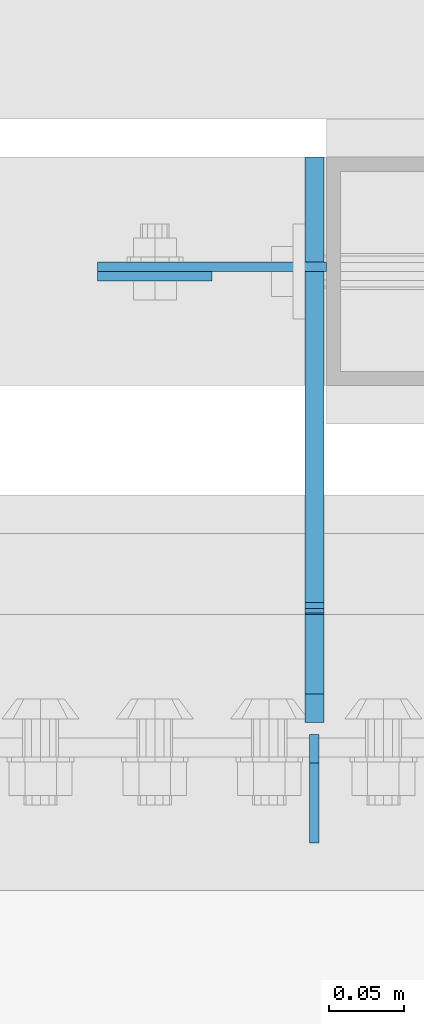
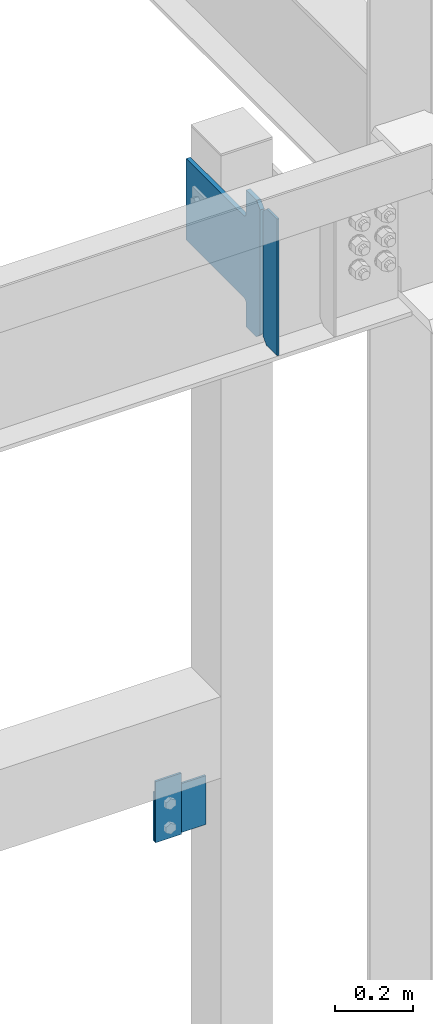
# One storey, part 3459 of 3843: 4 plates, 3 elements without a shape of their own.
"""IFC2X3 building model written with IfcOpenShell, lengths in millimetres."""

from ifc_helpers import new_model, si_unit, frame, origin_with_axes, place, context, subcontext, project, spatial, faceted_brep, material, type_object, element, aggregate, save


model = new_model("IFC2X3")

# Units and contexts
model_context = context("Model", 3, precision=1e-05, world=origin_with_axes())
body_context = subcontext(model_context, "Body", "Model", "MODEL_VIEW")
ifc_project = project(units=[si_unit("LENGTHUNIT", "METRE", prefix="MILLI"), si_unit("AREAUNIT", "SQUARE_METRE"), si_unit("VOLUMEUNIT", "CUBIC_METRE"), si_unit("MASSUNIT", "GRAM", prefix="KILO"), si_unit("TIMEUNIT", "SECOND"), si_unit("PLANEANGLEUNIT", "RADIAN"), si_unit("SOLIDANGLEUNIT", "STERADIAN"), si_unit("THERMODYNAMICTEMPERATUREUNIT", "DEGREE_CELSIUS"), si_unit("LUMINOUSINTENSITYUNIT", "LUMEN")], contexts=[model_context])

# Site, building, storey
site_placement = place(None, origin_with_axes())
site = spatial("IfcSite", under=ifc_project, at=site_placement, CompositionType="ELEMENT")
building_placement = place(site_placement, origin_with_axes())
building = spatial("IfcBuilding", under=site, at=building_placement, Name="Undefined", CompositionType="ELEMENT")
storey_placement = place(building_placement, origin_with_axes())
storey = spatial("IfcBuildingStorey", under=building, at=storey_placement, Name="Undefined", CompositionType="ELEMENT", Elevation=0.0)

# Assembly, plate
assembly_1_placement = place(storey_placement, origin_with_axes())
assembly_1 = element("IfcElementAssembly", 1, at=assembly_1_placement, inside=storey, Name="POST", AssemblyPlace="NOTDEFINED", PredefinedType="RIGID_FRAME")
ifc_material = material(Name="STEEL/A572-50")
plate_type_1 = type_object("IfcPlateType", PredefinedType="NOTDEFINED")
plate_1_placement = place(assembly_1_placement, frame((48412.4, 92522.675, 34455.1), z_axis=(0.0, 0.0, -1.0), x_axis=(-1.0, 0.0, 0.0)))
plate_1 = element("IfcPlate", 2, at=plate_1_placement, type_object=plate_type_1, material=ifc_material, Name="PLATE", context=body_context, shape_type="Brep", body=[
    faceted_brep([(0.0, -3.17499999999927, 0.0), (1.52795109897852e-10, -3.17500000000291, 152.400000000009), (1.52795109897852e-10, 3.17500000000291, 152.400000000009), (0.0, 3.17499999999927, 0.0), (152.399993896484, -3.17500000000291, 152.399993896484), (152.399993896484, 3.17500000000291, 152.399993896484), (152.399998474109, -3.17500000000291, 0.0), (152.399998474109, 3.17500000000291, 0.0)], [[[0, 1, 2, 3]], [[1, 4, 5, 2]], [[4, 6, 7, 5]], [[6, 0, 3, 7]], [[5, 7, 3, 2]], [[6, 4, 1, 0]]]),
])
aggregate(assembly_1, [plate_1])

assembly_2_placement = place(storey_placement, origin_with_axes())
assembly_2 = element("IfcElementAssembly", 3, at=assembly_2_placement, inside=storey, Name="BEAM", AssemblyPlace="NOTDEFINED", PredefinedType="RIGID_FRAME")
plate_type_2 = type_object("IfcPlateType", PredefinedType="NOTDEFINED")
plate_2_placement = place(assembly_2_placement, frame((48260.0000061035, 92516.325, 34302.7000061036), z_axis=(1.0, 0.0, 0.0), x_axis=(0.0, 0.0, 1.0)))
plate_2 = element("IfcPlate", 4, at=plate_2_placement, type_object=plate_type_2, material=ifc_material, Name="PLATE", context=body_context, shape_type="Brep", body=[
    faceted_brep([(0.0, -3.17499999999927, 0.0), (0.0, -3.17499999999927, 76.1999969482422), (0.0, 3.17499999999927, 76.1999969482422), (0.0, 3.17499999999927, 0.0), (190.5, -3.17500000000291, 76.1999969482422), (190.5, 3.17500000000291, 76.1999969482422), (190.5, -3.17500000000291, -3.63797880709171e-12), (190.5, 3.17500000000291, -3.63797880709171e-12)], [[[0, 1, 2, 3]], [[1, 4, 5, 2]], [[4, 6, 7, 5]], [[6, 0, 3, 7]], [[5, 7, 3, 2]], [[6, 4, 1, 0]]]),
])
aggregate(assembly_2, [plate_2])

# Assembly, plates
assembly_3_placement = place(storey_placement, origin_with_axes())
assembly_3 = element("IfcElementAssembly", 5, at=assembly_3_placement, inside=storey, Name="BEAM", AssemblyPlace="NOTDEFINED", PredefinedType="RIGID_FRAME")
plate_type_3 = type_object("IfcPlateType", PredefinedType="NOTDEFINED")
plate_3_placement = place(assembly_3_placement, frame((48404.4625, 92138.5, 35996.5625), z_axis=(0.0, 0.0, 1.0), x_axis=(0.0, 1.0, 0.0)))
plate_3 = element("IfcPlate", 6, at=plate_3_placement, type_object=plate_type_3, material=ifc_material, Name="PLATE", context=body_context, shape_type="Brep", body=[
    faceted_brep([(0.0, -3.17499999999927, 0.0), (0.0, -3.17500000000291, 425.449999999997), (0.0, 3.17500000000291, 425.449999999997), (0.0, 3.17499999999927, 0.0), (53.1812477111816, -3.17500000000291, 425.450012207031), (53.1812477111816, 3.17500000000291, 425.450012207031), (72.2312469482422, -3.17500000000291, 406.400012969971), (72.2312469482422, 3.17500000000291, 406.400012969971), (72.2312469482422, -3.17500000000291, 19.0499992370605), (72.2312469482422, 3.17500000000291, 19.0499992370605), (53.1812477111816, -3.17500000000291, 0.0), (53.1812477111816, 3.17500000000291, 0.0)], [[[0, 1, 2, 3]], [[1, 4, 5, 2]], [[4, 6, 7, 5]], [[6, 8, 9, 7]], [[8, 10, 11, 9]], [[10, 0, 3, 11]], [[5, 7, 9, 11, 3, 2]], [[10, 8, 6, 4, 1, 0]]]),
])
plate_type_4 = type_object("IfcPlateType", PredefinedType="NOTDEFINED")
plate_4_placement = place(assembly_3_placement, frame((48404.4625, 92218.66875, 35996.5625), z_axis=(0.0, 0.0, 1.0), x_axis=(0.0, 1.0, 0.0)))
plate_4 = element("IfcPlate", 7, at=plate_4_placement, type_object=plate_type_4, material=ifc_material, Name="PLATE", context=body_context, shape_type="Brep", body=[
    faceted_brep([(0.0, -6.34999999999854, 19.0499992370605), (0.0, -6.34999999999854, 406.400000762937), (0.0, 6.34999999999854, 406.400000762937), (0.0, 6.34999999999854, 19.0499992370605), (19.0499992370605, -6.34999999999854, 425.449999999997), (19.0499992370605, 6.34999999999854, 425.449999999997), (72.2312469482422, -6.35000000000582, 425.450012207031), (72.2312469482422, 6.35000000000582, 425.450012207031), (72.2312469482422, -6.35000000000582, 350.837505912779), (72.2312469482422, 6.35000000000582, 350.837505912779), (73.1979768708261, -6.35000000000582, 345.977426394733), (73.1979768708261, 6.35000000000582, 345.977426394733), (75.9509907713073, -6.35000000000582, 341.857249926579), (75.9509907713073, 6.35000000000582, 341.857249926579), (80.0711672394682, -6.35000000000582, 339.104236026105), (80.0711672394682, 6.35000000000582, 339.104236026105), (84.9312467575073, -6.35000000000582, 338.137506103514), (84.9312467575073, 6.35000000000582, 338.137506103514), (377.03125, -6.35000000000582, 338.137506103514), (377.03125, 6.35000000000582, 338.137506103514), (377.03125, -6.35000000000582, 84.1374969482422), (377.03125, 6.35000000000582, 84.1374969482422), (84.9312467575073, -6.35000000000582, 84.1374969482422), (84.9312467575073, 6.35000000000582, 84.1374969482422), (80.0711672394682, -6.35000000000582, 83.170767025651), (80.0711672394682, 6.35000000000582, 83.170767025651), (75.9509907713073, -6.35000000000582, 80.4177531251771), (75.9509907713073, 6.35000000000582, 80.4177531251771), (73.1979768708261, -6.35000000000582, 76.2975766570235), (73.1979768708261, 6.35000000000582, 76.2975766570235), (72.2312469482422, -6.35000000000582, 71.4374971389771), (72.2312469482422, 6.35000000000582, 71.4374971389771), (72.2312469482422, -6.35000000000582, 0.0), (72.2312469482422, 6.35000000000582, 0.0), (19.0499992370605, -6.34999999999854, 0.0), (19.0499992370605, 6.34999999999854, 0.0)], [[[0, 1, 2, 3]], [[1, 4, 5, 2]], [[4, 6, 7, 5]], [[6, 8, 9, 7]], [[8, 10, 11, 9]], [[10, 12, 13, 11]], [[12, 14, 15, 13]], [[14, 16, 17, 15]], [[16, 18, 19, 17]], [[18, 20, 21, 19]], [[20, 22, 23, 21]], [[22, 24, 25, 23]], [[24, 26, 27, 25]], [[26, 28, 29, 27]], [[28, 30, 31, 29]], [[30, 32, 33, 31]], [[32, 34, 35, 33]], [[34, 0, 3, 35]], [[5, 7, 9, 11, 13, 15, 17, 19, 21, 23, 25, 27, 29, 31, 33, 35, 3, 2]], [[34, 32, 30, 28, 26, 24, 22, 20, 18, 16, 14, 12, 10, 8, 6, 4, 1, 0]]]),
])
aggregate(assembly_3, [plate_3, plate_4])

save(model, "model.ifc")
